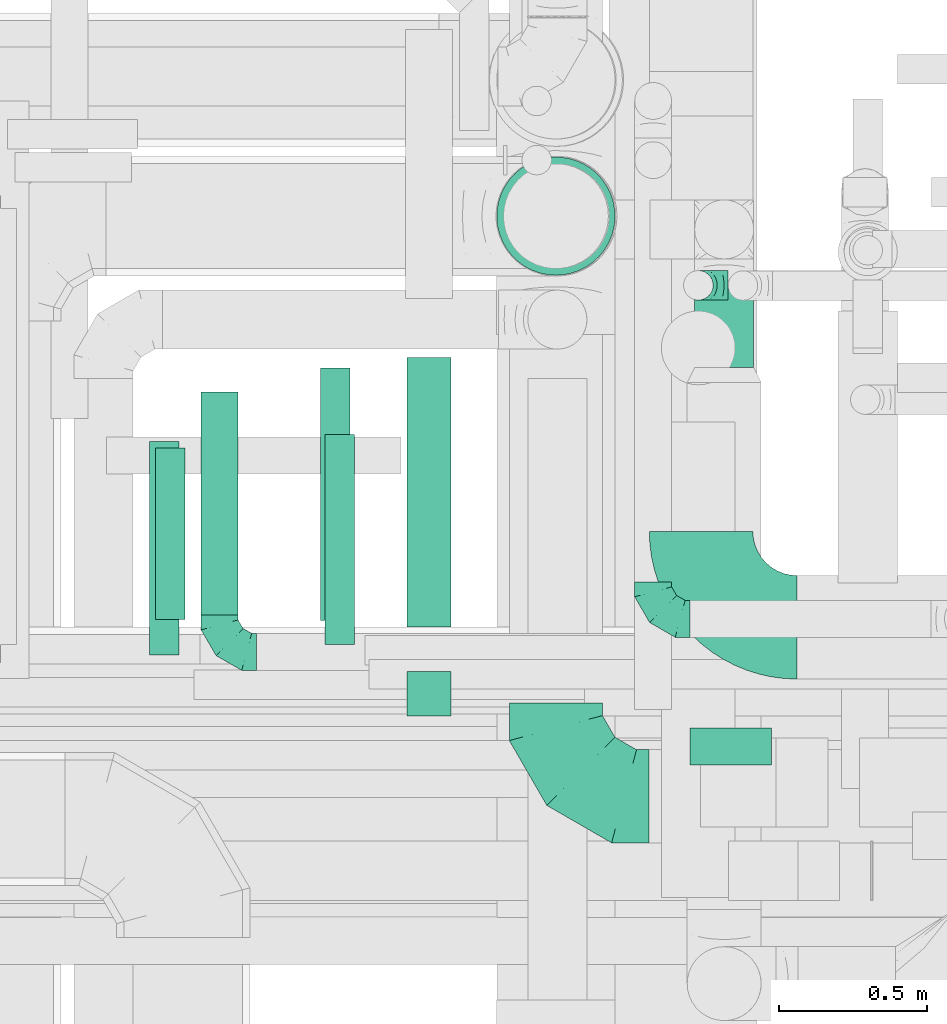
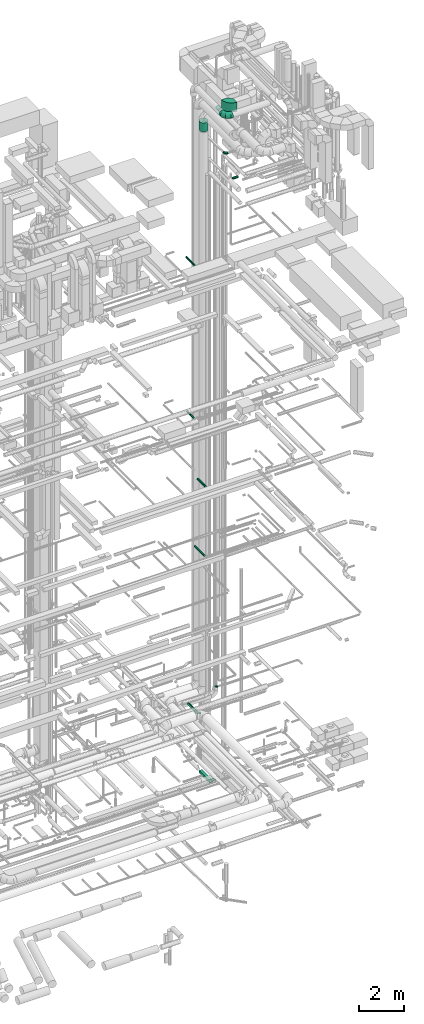
# One storey, part 260 of 337: 10 flow segments, 5 flow fittings.
"""IFC2X3 building model written with IfcOpenShell, lengths in millimetres."""

import ifcopenshell
import ifcopenshell.guid

model = None  # the IFC model being written
_history = None  # IfcOwnerHistory: only IFC2X3 demands one
_inside = {}  # id of a spatial element -> (the spatial element, [elements in it])
_under = {}  # id of a project, library or spatial element -> (it, [spatial elements below it])
_declared = {}  # id of a project -> (the project, [libraries it declares])
_typed = {}  # id of a type object -> (the type object, [elements of that type])
_made_of = {}  # id of a material, layer set ... -> (it, [elements and type objects made of it])


def new_model(schema):
    """Start an empty IFC model of exactly this schema.

    Asked for "IFC4X3", IfcOpenShell would pick the latest addendum, in which some entities
    have other attributes; the version numbers below select the first issue.
    IFC2X3 requires an IfcOwnerHistory on every rooted entity: one is made here for all.
    """
    global model, _history
    if schema == "IFC4X3":
        model = ifcopenshell.file(schema_version=(4, 3, 0, 0))
    else:
        model = ifcopenshell.file(schema=schema)
    _inside.clear()
    _under.clear()
    _declared.clear()
    _typed.clear()
    _made_of.clear()
    _history = None
    if model.schema == "IFC2X3":
        org = make("IfcOrganization", Name="unknown")
        user = make(
            "IfcPersonAndOrganization",
            ThePerson=make("IfcPerson", FamilyName="unknown"),
            TheOrganization=org,
        )
        app = make(
            "IfcApplication",
            ApplicationDeveloper=org,
            Version="unknown",
            ApplicationFullName="unknown",
            ApplicationIdentifier="unknown",
        )
        _history = make(
            "IfcOwnerHistory",
            OwningUser=user,
            OwningApplication=app,
            ChangeAction="ADDED",
            CreationDate=0,
        )
    return model


def make(cls, **values):
    """One entity of the class cls with the attributes given. An attribute that is None is left unset."""
    return model.create_entity(
        cls, **{name: value for name, value in values.items() if value is not None}
    )


def entity(cls, *values):
    """Any entity or typed value of the class cls, its attributes in the order of the schema. None: left unset."""
    e = model.create_entity(cls)
    for i, value in enumerate(values):
        if value is not None:
            e[i] = value
    return e


def rooted(cls, **values):
    """An entity with a GlobalId (a new one), such as an element, a storey or a relation."""
    return make(cls, GlobalId=ifcopenshell.guid.new(), OwnerHistory=_history, **values)


def si_unit(unit_type, name, prefix=None):
    """IfcSIUnit, for example si_unit("LENGTHUNIT", "METRE", prefix="MILLI")."""
    return make("IfcSIUnit", UnitType=unit_type, Prefix=prefix, Name=name)


def converted_unit(unit_type, name, factor, base, dimensions=None, offset=None):
    """IfcConversionBasedUnit, such as the inch: factor (a typed value) times the base unit."""
    return make(
        "IfcConversionBasedUnit"
        if offset is None
        else "IfcConversionBasedUnitWithOffset",
        ConversionOffset=offset,
        Dimensions=None
        if dimensions is None
        else entity("IfcDimensionalExponents", *dimensions),
        UnitType=unit_type,
        Name=name,
        ConversionFactor=make(
            "IfcMeasureWithUnit", ValueComponent=factor, UnitComponent=base
        ),
    )


def derived_unit(unit_type, elements):
    """IfcDerivedUnit: a product of units, each with its exponent."""
    return make(
        "IfcDerivedUnit",
        Elements=[
            make("IfcDerivedUnitElement", Unit=unit, Exponent=power)
            for unit, power in elements
        ],
        UnitType=unit_type,
    )


def assignment(units):
    """IfcUnitAssignment: the units of a project."""
    return None if units is None else make("IfcUnitAssignment", Units=units)


def point(xyz):
    """IfcCartesianPoint."""
    return None if xyz is None else make("IfcCartesianPoint", Coordinates=xyz)


def direction(xyz):
    """IfcDirection."""
    return None if xyz is None else make("IfcDirection", DirectionRatios=xyz)


def frame(location, z_axis=None, x_axis=None):
    """IfcAxis2Placement3D, a coordinate frame: its origin and axes. An axis left out is left unset."""
    return make(
        "IfcAxis2Placement3D",
        Location=point(location),
        Axis=direction(z_axis),
        RefDirection=direction(x_axis),
    )


def frame_2d(location, x_axis=None):
    """IfcAxis2Placement2D, a coordinate frame in the plane: its origin and x axis."""
    return make(
        "IfcAxis2Placement2D", Location=point(location), RefDirection=direction(x_axis)
    )


def origin():
    """The frame at (0, 0, 0) with its axes left unset."""
    return frame((0.0, 0.0, 0.0))


def origin_2d_with_axis():
    """The frame at (0, 0) in the plane with the x axis (1, 0) written out."""
    return frame_2d((0.0, 0.0), x_axis=(1.0, 0.0))


def place(relative_to, where):
    """IfcLocalPlacement: puts the frame where relative to a parent placement (None: the world)."""
    return make(
        "IfcLocalPlacement", PlacementRelTo=relative_to, RelativePlacement=where
    )


def context(
    kind, dimensions, precision=None, world=None, true_north=None, identifier=None
):
    """IfcGeometricRepresentationContext, for example the 3D "Model" context."""
    return make(
        "IfcGeometricRepresentationContext",
        ContextIdentifier=identifier,
        ContextType=kind,
        CoordinateSpaceDimension=dimensions,
        Precision=precision,
        WorldCoordinateSystem=world,
        TrueNorth=true_north,
    )


def subcontext(parent, identifier, kind, view, scale=None):
    """IfcGeometricRepresentationSubContext, for example "Body" below "Model"."""
    return make(
        "IfcGeometricRepresentationSubContext",
        ContextIdentifier=identifier,
        ContextType=kind,
        ParentContext=parent,
        TargetScale=scale,
        TargetView=view,
    )


def project(units=None, contexts=None):
    """IfcProject with its units and contexts."""
    return rooted(
        "IfcProject",
        Name="project",
        RepresentationContexts=contexts,
        UnitsInContext=assignment(units),
    )


def spatial(cls, under=None, at=None, **own):
    """A site, building, storey or space (cls), placed at a placement, below another one or the project."""
    s = rooted(cls, ObjectPlacement=at, **own)
    if under is not None:
        _under.setdefault(under.id(), (under, []))[1].append(s)
    return s


def polyline(points):
    """IfcPolyline through the points."""
    return make("IfcPolyline", Points=[point(p) for p in points])


def circle_curve(where, radius):
    """IfcCircle in the frame where."""
    return make("IfcCircle", Position=where, Radius=radius)


def parameter(value):
    """IfcParameterValue: where a trimmed curve begins or ends, as a parameter of its basis curve."""
    return model.create_entity("IfcParameterValue", value)


def trimmed(basis, trim1, trim2, sense, master):
    """IfcTrimmedCurve: the piece of a basis curve between two trims."""
    return make(
        "IfcTrimmedCurve",
        BasisCurve=basis,
        Trim1=trim1,
        Trim2=trim2,
        SenseAgreement=sense,
        MasterRepresentation=master,
    )


def segment(curve, same_sense, transition):
    """IfcCompositeCurveSegment."""
    return make(
        "IfcCompositeCurveSegment",
        Transition=transition,
        SameSense=same_sense,
        ParentCurve=curve,
    )


def composite_curve(segments, self_intersect=None):
    """IfcCompositeCurve: segments joined end to end."""
    return make("IfcCompositeCurve", Segments=segments, SelfIntersect=self_intersect)


def profile(cls, at=None, kind="AREA", **sizes):
    """A parametric profile (cls). Its sizes go by their IFC names, for example OverallWidth=200.0."""
    return make(cls, ProfileType=kind, Position=at, **sizes)


def rectangle(**sizes):
    """IfcRectangleProfileDef."""
    return profile("IfcRectangleProfileDef", **sizes)


def circle(**sizes):
    """IfcCircleProfileDef."""
    return profile("IfcCircleProfileDef", **sizes)


def outline(outer, holes=None, kind="AREA"):
    """IfcArbitraryClosedProfileDef: a profile drawn as a closed curve; with holes, ...WithVoids."""
    if holes is None:
        return make("IfcArbitraryClosedProfileDef", ProfileType=kind, OuterCurve=outer)
    return make(
        "IfcArbitraryProfileDefWithVoids",
        ProfileType=kind,
        OuterCurve=outer,
        InnerCurves=holes,
    )


def extrude(swept, where, along, depth):
    """IfcExtrudedAreaSolid: the profile swept, set in the frame where, extruded along a direction by depth."""
    return make(
        "IfcExtrudedAreaSolid",
        SweptArea=swept,
        Position=where,
        ExtrudedDirection=direction(along),
        Depth=depth,
    )


def faces_of(points, faces, orient=None, outer=None):
    """IfcFace entities. A face is a list of loops; a loop is a list of indices into points, from 0.

    orient and outer hold one flag for each loop. By default every Orientation is true, the
    first loop of a face is its IfcFaceOuterBound and the others are IfcFaceBound.
    """
    made = []
    for i, loops in enumerate(faces):
        bounds = []
        for j, loop in enumerate(loops):
            is_outer = j == 0 if outer is None else outer[i][j]
            bounds.append(
                make(
                    "IfcFaceOuterBound" if is_outer else "IfcFaceBound",
                    Bound=make("IfcPolyLoop", Polygon=[points[k] for k in loop]),
                    Orientation=True if orient is None else orient[i][j],
                )
            )
        made.append(make("IfcFace", Bounds=bounds))
    return made


def faceted_brep(points, faces, orient=None, outer=None, voids=None):
    """IfcFacetedBrep: a solid bounded by flat faces; with voids (closed shells), ...WithVoids."""
    shared = [point(p) for p in points]
    hull = make("IfcClosedShell", CfsFaces=faces_of(shared, faces, orient, outer))
    if voids is None:
        return make("IfcFacetedBrep", Outer=hull)
    return make(
        "IfcFacetedBrepWithVoids",
        Outer=hull,
        Voids=[
            make(cls, CfsFaces=faces_of(shared, fs, o, b)) for cls, fs, o, b in voids
        ],
    )


def shape(context_of_items, identifier, shape_type, items):
    """IfcShapeRepresentation: the items that make up one representation, for example the "Body"."""
    return make(
        "IfcShapeRepresentation",
        ContextOfItems=context_of_items,
        RepresentationIdentifier=identifier,
        RepresentationType=shape_type,
        Items=items,
    )


def source(mapping_origin, context_of_items, identifier, shape_type, items):
    """IfcRepresentationMap: a shape defined once, which mapped items show again and again."""
    return make(
        "IfcRepresentationMap",
        MappingOrigin=mapping_origin,
        MappedRepresentation=shape(context_of_items, identifier, shape_type, items),
    )


def transform(
    local_origin,
    x_axis=None,
    y_axis=None,
    z_axis=None,
    scale=None,
    scale2=None,
    scale3=None,
    uniform=True,
):
    """IfcCartesianTransformationOperator3D, or its non-uniform kind. x_axis, y_axis, z_axis: its Axis1, 2, 3."""
    if uniform:
        return make(
            "IfcCartesianTransformationOperator3D",
            Axis1=direction(x_axis),
            Axis2=direction(y_axis),
            LocalOrigin=point(local_origin),
            Scale=scale,
            Axis3=direction(z_axis),
        )
    return make(
        "IfcCartesianTransformationOperator3DnonUniform",
        Axis1=direction(x_axis),
        Axis2=direction(y_axis),
        LocalOrigin=point(local_origin),
        Scale=scale,
        Axis3=direction(z_axis),
        Scale2=scale2,
        Scale3=scale3,
    )


def mapped(mapping_source, mapping_target):
    """IfcMappedItem: shows the shape of a source again, moved by a transform."""
    return make(
        "IfcMappedItem", MappingSource=mapping_source, MappingTarget=mapping_target
    )


def material(Name=None, Category=None):
    """IfcMaterial."""
    return make("IfcMaterial", Name=Name, Category=Category)


def made_of(thing, what):
    """Note that an element or type object is made of a material, layer set ...; save() writes the relation."""
    if what is not None:
        _made_of.setdefault(what.id(), (what, []))[1].append(thing)
    return thing


def type_object(cls, material=None, **own):
    """A type object (cls), such as IfcWallType, which elements share."""
    return made_of(rooted(cls, **own), material)


def type_shapes(of_type, sources):
    """Give a type object the sources (RepresentationMaps) that its elements show as mapped items."""
    of_type.RepresentationMaps = sources


def element(
    cls,
    number,
    at=None,
    inside=None,
    cuts=None,
    type_object=None,
    material=None,
    context=None,
    identifier="Body",
    shape_type=None,
    held_by="IfcProductDefinitionShape",
    body=None,
    shapes=None,
    **own,
):
    """One element of the class cls, such as IfcWall. Its Tag is "e" and its number.

    at: its placement. inside: the storey or other place that contains it. cuts: it is an
    opening in that element (IfcRelVoidsElement). A single representation is given by context,
    identifier, shape_type and body (its items); several are given by shapes. held_by: the class
    of the entity that holds the representations. save() writes the other relations.
    """
    e = rooted(cls, Tag="e%d" % number, ObjectPlacement=at, **own)
    if body is not None:
        shapes = [shape(context, identifier, shape_type, body)]
    if shapes is not None:
        e.Representation = make(held_by, Representations=shapes)
    if inside is not None:
        _inside.setdefault(inside.id(), (inside, []))[1].append(e)
    if cuts is not None:
        rooted(
            "IfcRelVoidsElement", RelatingBuildingElement=cuts, RelatedOpeningElement=e
        )
    if type_object is not None:
        _typed.setdefault(type_object.id(), (type_object, []))[1].append(e)
    return made_of(e, material)


def aggregate(whole, parts):
    """IfcRelAggregates: a whole, such as a stair, and the parts it consists of."""
    return rooted("IfcRelAggregates", RelatingObject=whole, RelatedObjects=parts)


def save(model, path):
    """Write the relations noted so far, then the file.

    IfcRelAggregates (storeys below a building ...), IfcRelContainedInSpatialStructure (elements
    in a storey), IfcRelDefinesByType, IfcRelAssociatesMaterial and IfcRelDeclares: one each for
    every whole, place, type object, material and project.
    """
    for whole, parts in _under.values():
        aggregate(whole, parts)
    for where, things in _inside.values():
        rooted(
            "IfcRelContainedInSpatialStructure",
            RelatedElements=things,
            RelatingStructure=where,
        )
    for kind, things in _typed.values():
        rooted("IfcRelDefinesByType", RelatedObjects=things, RelatingType=kind)
    for what, things in _made_of.values():
        rooted("IfcRelAssociatesMaterial", RelatedObjects=things, RelatingMaterial=what)
    for by, libraries in _declared.values():
        rooted("IfcRelDeclares", RelatingContext=by, RelatedDefinitions=libraries)
    model.write(path)


model = new_model("IFC2X3")

# Units and contexts
model_context = context("Model", 3, precision=0.01, world=origin(), true_north=direction((6.12303176911189e-17, 1.0)))
body_context = subcontext(model_context, "Body", "Model", "MODEL_VIEW")
ifc_project = project(units=[si_unit("LENGTHUNIT", "METRE", prefix="MILLI"), si_unit("AREAUNIT", "SQUARE_METRE"), si_unit("VOLUMEUNIT", "CUBIC_METRE"), converted_unit("PLANEANGLEUNIT", "DEGREE", entity("IfcRatioMeasure", 0.0174532925199433), si_unit("PLANEANGLEUNIT", "RADIAN"), dimensions=[0, 0, 0, 0, 0, 0, 0]), si_unit("MASSUNIT", "GRAM", prefix="KILO"), derived_unit("MASSDENSITYUNIT", [(si_unit("MASSUNIT", "GRAM", prefix="KILO"), 1), (si_unit("LENGTHUNIT", "METRE"), -3)]), derived_unit("MOMENTOFINERTIAUNIT", [(si_unit("LENGTHUNIT", "METRE"), 4)]), si_unit("TIMEUNIT", "SECOND"), si_unit("FREQUENCYUNIT", "HERTZ"), si_unit("THERMODYNAMICTEMPERATUREUNIT", "DEGREE_CELSIUS"), derived_unit("THERMALTRANSMITTANCEUNIT", [(si_unit("MASSUNIT", "GRAM", prefix="KILO"), 1), (si_unit("THERMODYNAMICTEMPERATUREUNIT", "KELVIN"), -1), (si_unit("TIMEUNIT", "SECOND"), -3)]), derived_unit("VOLUMETRICFLOWRATEUNIT", [(si_unit("LENGTHUNIT", "METRE"), 3), (si_unit("TIMEUNIT", "SECOND"), -1)]), derived_unit("MASSFLOWRATEUNIT", [(si_unit("MASSUNIT", "GRAM", prefix="KILO"), 1), (si_unit("TIMEUNIT", "SECOND"), -1)]), derived_unit("ROTATIONALFREQUENCYUNIT", [(si_unit("TIMEUNIT", "SECOND"), -1)]), si_unit("ELECTRICCURRENTUNIT", "AMPERE"), si_unit("ELECTRICVOLTAGEUNIT", "VOLT"), si_unit("POWERUNIT", "WATT"), si_unit("FORCEUNIT", "NEWTON", prefix="KILO"), si_unit("ILLUMINANCEUNIT", "LUX"), si_unit("LUMINOUSFLUXUNIT", "LUMEN"), si_unit("LUMINOUSINTENSITYUNIT", "CANDELA"), derived_unit("USERDEFINED", [(si_unit("MASSUNIT", "GRAM", prefix="KILO"), -1), (si_unit("LENGTHUNIT", "METRE"), -2), (si_unit("TIMEUNIT", "SECOND"), 3), (si_unit("LUMINOUSFLUXUNIT", "LUMEN"), 1)]), derived_unit("LINEARVELOCITYUNIT", [(si_unit("LENGTHUNIT", "METRE"), 1), (si_unit("TIMEUNIT", "SECOND"), -1)]), si_unit("PRESSUREUNIT", "PASCAL"), derived_unit("USERDEFINED", [(si_unit("LENGTHUNIT", "METRE"), -2), (si_unit("MASSUNIT", "GRAM", prefix="KILO"), 1), (si_unit("TIMEUNIT", "SECOND"), -2)]), derived_unit("LINEARFORCEUNIT", [(si_unit("MASSUNIT", "GRAM", prefix="KILO"), 1), (si_unit("LENGTHUNIT", "METRE"), 1), (si_unit("TIMEUNIT", "SECOND"), -2), (si_unit("LENGTHUNIT", "METRE"), -1)]), derived_unit("PLANARFORCEUNIT", [(si_unit("MASSUNIT", "GRAM", prefix="KILO"), 1), (si_unit("LENGTHUNIT", "METRE"), 1), (si_unit("TIMEUNIT", "SECOND"), -2), (si_unit("LENGTHUNIT", "METRE"), -2)])], contexts=[model_context])

# Site, building, storey
site_placement = place(None, origin())
site = spatial("IfcSite", under=ifc_project, at=site_placement, CompositionType="ELEMENT")
building_placement = place(site_placement, origin())
building = spatial("IfcBuilding", under=site, at=building_placement, CompositionType="ELEMENT")
storey_placement = place(building_placement, origin())
storey = spatial("IfcBuildingStorey", under=building, at=storey_placement, CompositionType="ELEMENT", Elevation=0.0)

# Flow segments
duct_segment_type_1 = type_object("IfcDuctSegmentType", PredefinedType="NOTDEFINED")
flow_segment_1_placement = place(storey_placement, frame((67054.73, 10099.06, -675.0)))
element("IfcFlowSegment", 1, at=flow_segment_1_placement, inside=storey, type_object=duct_segment_type_1, context=body_context, shape_type="SweptSolid", body=[
    extrude(rectangle(XDim=150.000000000001, YDim=150.000000000001, at=origin_2d_with_axis()), frame((75.0, 75.0, 0.0), z_axis=(0.0, 0.0, 1.0), x_axis=(0.0, 1.0, 0.0)), (0.0, 0.0, 1.0), 30.0000000000121),
])
flow_segment_2_placement = place(storey_placement, frame((67054.73, 10399.06, -975.0)))
element("IfcFlowSegment", 2, at=flow_segment_2_placement, inside=storey, type_object=duct_segment_type_1, context=body_context, shape_type="SweptSolid", body=[
    extrude(rectangle(XDim=912.000000000007, YDim=150.000000000001, at=origin_2d_with_axis()), frame((75.0, 456.0, 0.0), z_axis=(0.0, 0.0, 1.0), x_axis=(0.0, 1.0, 0.0)), (0.0, 0.0, 1.0), 150.0),
])
duct_segment_type_2 = type_object("IfcDuctSegmentType", PredefinedType="NOTDEFINED")
flow_segment_3_placement = place(storey_placement, frame((66776.28, 10340.36, 15248.4)))
element("IfcFlowSegment", 3, at=flow_segment_3_placement, inside=storey, type_object=duct_segment_type_2, context=body_context, shape_type="SweptSolid", body=[
    extrude(circle(Radius=50.0, at=origin_2d_with_axis()), frame((51.6, 0.0, 51.6), z_axis=(0.0, 1.0, 0.0), x_axis=(1.0, 0.0, 0.0)), (0.0, 0.0, 1.0), 710.000000000005),
])
flow_segment_4_placement = place(storey_placement, frame((66761.5, 10421.33, 11448.4)))
element("IfcFlowSegment", 4, at=flow_segment_4_placement, inside=storey, type_object=duct_segment_type_2, context=body_context, shape_type="SweptSolid", body=[
    extrude(circle(Radius=50.0, at=origin_2d_with_axis()), frame((51.6, 0.0, 51.6), z_axis=(0.0, 1.0, 0.0), x_axis=(1.0, 0.0, 0.0)), (0.0, 0.0, 1.0), 855.000000000018),
])
flow_segment_5_placement = place(storey_placement, frame((66357.85, 10440.5, 3035.9)))
element("IfcFlowSegment", 5, at=flow_segment_5_placement, inside=storey, type_object=duct_segment_type_2, context=body_context, shape_type="SweptSolid", body=[
    extrude(circle(Radius=62.5, at=origin_2d_with_axis()), frame((64.1, 0.0, 64.1), z_axis=(0.0, 1.0, 0.0), x_axis=(1.0, 0.0, 0.0)), (0.0, 0.0, 1.0), 754.74944733785),
])
flow_segment_6_placement = place(storey_placement, frame((66203.23, 10425.19, 19148.4)))
element("IfcFlowSegment", 6, at=flow_segment_6_placement, inside=storey, type_object=duct_segment_type_2, context=body_context, shape_type="SweptSolid", body=[
    extrude(circle(Radius=50.0, at=origin_2d_with_axis()), frame((51.6, 0.0, 51.6), z_axis=(0.0, 1.0, 0.0), x_axis=(1.0, 0.0, 0.0)), (0.0, 0.0, 1.0), 580.000000000011),
])
flow_segment_7_placement = place(storey_placement, frame((67357.45, 11587.56, 33630.0)))
element("IfcFlowSegment", 7, at=flow_segment_7_placement, inside=storey, type_object=duct_segment_type_2, context=body_context, shape_type="SweptSolid", body=[
    extrude(circle(Radius=200.0, at=origin_2d_with_axis()), frame((201.6, 201.6, 0.0), z_axis=(0.0, 0.0, 1.0), x_axis=(0.0, -1.0, 0.0)), (0.0, 0.0, 1.0), 490.000000420803),
])
flow_segment_8_placement = place(storey_placement, frame((68026.5, 11277.11, 34698.4)))
element("IfcFlowSegment", 8, at=flow_segment_8_placement, inside=storey, type_object=duct_segment_type_2, context=body_context, shape_type="SweptSolid", body=[
    extrude(circle(Radius=100.0, at=origin_2d_with_axis()), frame((101.6, 0.0, 101.6), z_axis=(0.0, 1.0, 0.0), x_axis=(1.0, 0.0, 0.0)), (0.0, 0.0, 1.0), 267.178690553049),
])
flow_segment_9_placement = place(storey_placement, frame((66183.28, 10305.08, 27548.4)))
element("IfcFlowSegment", 9, at=flow_segment_9_placement, inside=storey, type_object=duct_segment_type_2, context=body_context, shape_type="SweptSolid", body=[
    extrude(circle(Radius=50.0, at=origin_2d_with_axis()), frame((51.6, 0.0, 51.6), z_axis=(0.0, 1.0, 0.0), x_axis=(1.0, 0.0, 0.0)), (0.0, 0.0, 1.0), 722.500000000022),
])
flow_segment_10_placement = place(storey_placement, frame((68013.0, 9931.15, 31825.9)))
element("IfcFlowSegment", 10, at=flow_segment_10_placement, inside=storey, type_object=duct_segment_type_2, context=body_context, shape_type="SweptSolid", body=[
    extrude(circle(Radius=62.5, at=origin_2d_with_axis()), frame((0.0, 64.1, 64.1), z_axis=(1.0, 0.0, 0.0), x_axis=(0.0, 1.0, 0.0)), (0.0, 0.0, 1.0), 275.797196645982),
])

# Flow fittings
ifc_material = material()
duct_fitting_type_1 = type_object("IfcDuctFittingType", PredefinedType="NOTDEFINED", material=ifc_material)
shared_shape_1 = source(origin(), body_context, "Body", "Brep", [
    faceted_brep([(-100.0, 0.0, -50.0), (-100.0, -12.94, -48.3), (-100.0, -25.0, -43.3), (-100.0, -35.36, -35.36), (-100.0, -43.3, -25.0), (-100.0, -48.3, -12.94), (-100.0, -50.0, 0.0), (-100.0, -48.3, 12.94), (-100.0, -43.3, 25.0), (-100.0, -35.36, 35.36), (-100.0, -25.0, 43.3), (-100.0, -12.94, 48.3), (-100.0, 0.0, 50.0), (-100.0, 12.94, 48.3), (-100.0, 25.0, 43.3), (-100.0, 35.36, 35.36), (-100.0, 43.3, 25.0), (-100.0, 48.3, 12.94), (-100.0, 50.0, 0.0), (-100.0, 48.3, -12.94), (-100.0, 43.3, -25.0), (-100.0, 35.36, -35.36), (-100.0, 25.0, -43.3), (-100.0, 12.94, -48.3), (-76.67, 12.94, 48.3), (-79.9, 25.0, 43.3), (-73.21, 0.0, 50.0), (-82.68, 35.36, 35.36), (-86.15, 48.3, 12.94), (-86.6, 50.0, 0.0), (-84.81, 43.3, 25.0), (-84.81, 43.3, -25.0), (-82.68, 35.36, -35.36), (-86.15, 48.3, -12.94), (-76.67, 12.94, -48.3), (-73.21, 0.0, -50.0), (-79.9, 25.0, -43.3), (-69.74, -12.94, -48.3), (-66.51, -25.0, -43.3), (-63.73, -35.36, -35.36), (-61.6, -43.3, -25.0), (-60.26, -48.3, -12.94), (-59.81, -50.0, 0.0), (-60.26, -48.3, 12.94), (-61.6, -43.3, 25.0), (-63.73, -35.36, 35.36), (-66.51, -25.0, 43.3), (-69.74, -12.94, 48.3), (-36.27, 36.27, 48.3), (-45.1, 45.1, 43.3), (-26.79, 26.79, 50.0), (-52.68, 52.68, 35.36), (-58.49, 58.49, 25.0), (-62.15, 62.15, 12.94), (-63.4, 63.4, 0.0), (-62.15, 62.15, -12.94), (-58.49, 58.49, -25.0), (-52.68, 52.68, -35.36), (-36.27, 36.27, -48.3), (-26.79, 26.79, -50.0), (-45.1, 45.1, -43.3), (-17.32, 17.32, -48.3), (-8.49, 8.49, -43.3), (-0.91, 0.91, -35.36), (4.9, -4.9, -25.0), (8.56, -8.56, -12.94), (9.81, -9.81, 0.0), (8.56, -8.56, 12.94), (4.9, -4.9, 25.0), (-0.91, 0.91, 35.36), (-8.49, 8.49, 43.3), (-17.32, 17.32, 48.3), (-12.94, 76.67, 48.3), (-25.0, 79.9, 43.3), (0.0, 73.21, 50.0), (-35.36, 82.68, 35.36), (-43.3, 84.81, 25.0), (-48.3, 86.15, 12.94), (-50.0, 86.6, 0.0), (-48.3, 86.15, -12.94), (-43.3, 84.81, -25.0), (-35.36, 82.68, -35.36), (-12.94, 76.67, -48.3), (0.0, 73.21, -50.0), (-25.0, 79.9, -43.3), (12.94, 69.74, -48.3), (25.0, 66.51, -43.3), (35.36, 63.73, -35.36), (43.3, 61.6, -25.0), (48.3, 60.26, -12.94), (50.0, 59.81, 0.0), (48.3, 60.26, 12.94), (43.3, 61.6, 25.0), (35.36, 63.73, 35.36), (25.0, 66.51, 43.3), (12.94, 69.74, 48.3), (-12.94, 100.0, -48.3), (-25.0, 100.0, -43.3), (-35.36, 100.0, -35.36), (-43.3, 100.0, -25.0), (-48.3, 100.0, -12.94), (-50.0, 100.0, 0.0), (-48.3, 100.0, 12.94), (-43.3, 100.0, 25.0), (-35.36, 100.0, 35.36), (-25.0, 100.0, 43.3), (-12.94, 100.0, 48.3), (0.0, 100.0, 50.0), (12.94, 100.0, 48.3), (25.0, 100.0, 43.3), (35.36, 100.0, 35.36), (43.3, 100.0, 25.0), (48.3, 100.0, 12.94), (50.0, 100.0, 0.0), (48.3, 100.0, -12.94), (43.3, 100.0, -25.0), (35.36, 100.0, -35.36), (25.0, 100.0, -43.3), (12.94, 100.0, -48.3), (0.0, 100.0, -50.0)], [[[0, 1, 2, 3, 4, 5, 6, 7, 8, 9, 10, 11, 12, 13, 14, 15, 16, 17, 18, 19, 20, 21, 22, 23]], [[24, 25, 14, 13]], [[26, 24, 13, 12]], [[14, 25, 27, 15]], [[28, 29, 18, 17]], [[30, 28, 17, 16]], [[15, 27, 30, 16]], [[20, 31, 32, 21]], [[33, 31, 20, 19]], [[18, 29, 33, 19]], [[34, 35, 0, 23]], [[36, 34, 23, 22]], [[32, 36, 22, 21]], [[2, 1, 37, 38]], [[3, 2, 38, 39]], [[0, 35, 37, 1]], [[5, 4, 40, 41]], [[6, 5, 41, 42]], [[3, 39, 40, 4]], [[6, 42, 43, 7]], [[7, 43, 44, 8]], [[8, 44, 45, 9]], [[10, 46, 47, 11]], [[11, 47, 26, 12]], [[10, 9, 45, 46]], [[48, 49, 25, 24]], [[50, 48, 24, 26]], [[27, 25, 49, 51]], [[52, 53, 28, 30]], [[51, 52, 30, 27]], [[29, 28, 53, 54]], [[55, 56, 31, 33]], [[54, 55, 33, 29]], [[57, 32, 31, 56]], [[58, 59, 35, 34]], [[60, 58, 34, 36]], [[57, 60, 36, 32]], [[37, 35, 59, 61]], [[38, 37, 61, 62]], [[39, 38, 62, 63]], [[41, 40, 64, 65]], [[42, 41, 65, 66]], [[63, 64, 40, 39]], [[43, 42, 66, 67]], [[44, 43, 67, 68]], [[68, 69, 45, 44]], [[46, 45, 69, 70]], [[47, 46, 70, 71]], [[26, 47, 71, 50]], [[72, 73, 49, 48]], [[74, 72, 48, 50]], [[51, 49, 73, 75]], [[76, 77, 53, 52]], [[75, 76, 52, 51]], [[54, 53, 77, 78]], [[79, 80, 56, 55]], [[78, 79, 55, 54]], [[81, 57, 56, 80]], [[82, 83, 59, 58]], [[84, 82, 58, 60]], [[81, 84, 60, 57]], [[61, 59, 83, 85]], [[62, 61, 85, 86]], [[63, 62, 86, 87]], [[65, 64, 88, 89]], [[66, 65, 89, 90]], [[87, 88, 64, 63]], [[67, 66, 90, 91]], [[68, 67, 91, 92]], [[92, 93, 69, 68]], [[70, 69, 93, 94]], [[71, 70, 94, 95]], [[50, 71, 95, 74]], [[96, 97, 98, 99, 100, 101, 102, 103, 104, 105, 106, 107, 108, 109, 110, 111, 112, 113, 114, 115, 116, 117, 118, 119]], [[72, 74, 107, 106]], [[73, 72, 106, 105]], [[75, 73, 105, 104]], [[77, 76, 103, 102]], [[78, 77, 102, 101]], [[75, 104, 103, 76]], [[78, 101, 100, 79]], [[79, 100, 99, 80]], [[80, 99, 98, 81]], [[96, 119, 83, 82]], [[97, 96, 82, 84]], [[84, 81, 98, 97]], [[83, 119, 118, 85]], [[85, 118, 117, 86]], [[86, 117, 116, 87]], [[88, 115, 114, 89]], [[89, 114, 113, 90]], [[87, 116, 115, 88]], [[91, 90, 113, 112]], [[92, 91, 112, 111]], [[93, 92, 111, 110]], [[95, 94, 109, 108]], [[74, 95, 108, 107]], [[110, 109, 94, 93]]]),
])
type_shapes(duct_fitting_type_1, [shared_shape_1])
flow_fitting_1_placement = place(storey_placement, frame((68040.83, 11555.25, 3220.0), z_axis=(0.0, 1.0, 0.0), x_axis=(-1.0, 0.0, 0.0)))
element("IfcFlowFitting", 11, at=flow_fitting_1_placement, inside=storey, type_object=duct_fitting_type_1, material=ifc_material, context=body_context, shape_type="MappedRepresentation", body=[
    mapped(shared_shape_1, transform((0.0, 0.0, 0.0), scale=1.0)),
])
duct_fitting_type_2 = type_object("IfcDuctFittingType", PredefinedType="NOTDEFINED", material=ifc_material)
shared_shape_2 = source(origin(), body_context, "Body", "Brep", [
    faceted_brep([(-125.0, 0.0, -62.5), (-125.0, -16.18, -60.37), (-125.0, -31.25, -54.13), (-125.0, -44.19, -44.19), (-125.0, -54.13, -31.25), (-125.0, -60.37, -16.18), (-125.0, -62.5, 0.0), (-125.0, -60.37, 16.18), (-125.0, -54.13, 31.25), (-125.0, -44.19, 44.19), (-125.0, -31.25, 54.13), (-125.0, -16.18, 60.37), (-125.0, 0.0, 62.5), (-125.0, 16.18, 60.37), (-125.0, 31.25, 54.13), (-125.0, 44.19, 44.19), (-125.0, 54.13, 31.25), (-125.0, 60.37, 16.18), (-125.0, 62.5, 0.0), (-125.0, 60.37, -16.18), (-125.0, 54.13, -31.25), (-125.0, 44.19, -44.19), (-125.0, 31.25, -54.13), (-125.0, 16.18, -60.37), (-95.84, 16.18, 60.37), (-99.88, 31.25, 54.13), (-91.51, 0.0, 62.5), (-103.35, 44.19, 44.19), (-107.68, 60.37, 16.18), (-108.25, 62.5, 0.0), (-106.01, 54.13, 31.25), (-106.01, 54.13, -31.25), (-103.35, 44.19, -44.19), (-107.68, 60.37, -16.18), (-95.84, 16.18, -60.37), (-91.51, 0.0, -62.5), (-99.88, 31.25, -54.13), (-87.17, -16.18, -60.37), (-83.13, -31.25, -54.13), (-79.66, -44.19, -44.19), (-77.0, -54.13, -31.25), (-75.33, -60.37, -16.18), (-74.76, -62.5, 0.0), (-75.33, -60.37, 16.18), (-77.0, -54.13, 31.25), (-79.66, -44.19, 44.19), (-83.13, -31.25, 54.13), (-87.17, -16.18, 60.37), (-45.34, 45.34, 60.37), (-56.37, 56.37, 54.13), (-33.49, 33.49, 62.5), (-65.85, 65.85, 44.19), (-73.12, 73.12, 31.25), (-77.69, 77.69, 16.18), (-79.25, 79.25, 0.0), (-77.69, 77.69, -16.18), (-73.12, 73.12, -31.25), (-65.85, 65.85, -44.19), (-45.34, 45.34, -60.37), (-33.49, 33.49, -62.5), (-56.37, 56.37, -54.13), (-21.65, 21.65, -60.37), (-10.62, 10.62, -54.13), (-1.14, 1.14, -44.19), (6.13, -6.13, -31.25), (10.7, -10.7, -16.18), (12.26, -12.26, 0.0), (10.7, -10.7, 16.18), (6.13, -6.13, 31.25), (-1.14, 1.14, 44.19), (-10.62, 10.62, 54.13), (-21.65, 21.65, 60.37), (-16.18, 95.84, 60.37), (-31.25, 99.88, 54.13), (0.0, 91.51, 62.5), (-44.19, 103.35, 44.19), (-54.13, 106.01, 31.25), (-60.37, 107.68, 16.18), (-62.5, 108.25, 0.0), (-60.37, 107.68, -16.18), (-54.13, 106.01, -31.25), (-44.19, 103.35, -44.19), (-16.18, 95.84, -60.37), (0.0, 91.51, -62.5), (-31.25, 99.88, -54.13), (16.18, 87.17, -60.37), (31.25, 83.13, -54.13), (44.19, 79.66, -44.19), (54.13, 77.0, -31.25), (60.37, 75.33, -16.18), (62.5, 74.76, 0.0), (60.37, 75.33, 16.18), (54.13, 77.0, 31.25), (44.19, 79.66, 44.19), (31.25, 83.13, 54.13), (16.18, 87.17, 60.37), (-16.18, 125.0, -60.37), (-31.25, 125.0, -54.13), (-44.19, 125.0, -44.19), (-54.13, 125.0, -31.25), (-60.37, 125.0, -16.18), (-62.5, 125.0, 0.0), (-60.37, 125.0, 16.18), (-54.13, 125.0, 31.25), (-44.19, 125.0, 44.19), (-31.25, 125.0, 54.13), (-16.18, 125.0, 60.37), (0.0, 125.0, 62.5), (16.18, 125.0, 60.37), (31.25, 125.0, 54.13), (44.19, 125.0, 44.19), (54.13, 125.0, 31.25), (60.37, 125.0, 16.18), (62.5, 125.0, 0.0), (60.37, 125.0, -16.18), (54.13, 125.0, -31.25), (44.19, 125.0, -44.19), (31.25, 125.0, -54.13), (16.18, 125.0, -60.37), (0.0, 125.0, -62.5)], [[[0, 1, 2, 3, 4, 5, 6, 7, 8, 9, 10, 11, 12, 13, 14, 15, 16, 17, 18, 19, 20, 21, 22, 23]], [[24, 25, 14, 13]], [[26, 24, 13, 12]], [[14, 25, 27, 15]], [[28, 29, 18, 17]], [[30, 28, 17, 16]], [[15, 27, 30, 16]], [[20, 31, 32, 21]], [[33, 31, 20, 19]], [[18, 29, 33, 19]], [[34, 35, 0, 23]], [[36, 34, 23, 22]], [[21, 32, 36, 22]], [[1, 0, 35, 37]], [[2, 1, 37, 38]], [[38, 39, 3, 2]], [[5, 4, 40, 41]], [[6, 5, 41, 42]], [[39, 40, 4, 3]], [[6, 42, 43, 7]], [[7, 43, 44, 8]], [[45, 9, 8, 44]], [[9, 45, 46, 10]], [[10, 46, 47, 11]], [[26, 12, 11, 47]], [[48, 49, 25, 24]], [[50, 48, 24, 26]], [[27, 25, 49, 51]], [[52, 53, 28, 30]], [[51, 52, 30, 27]], [[29, 28, 53, 54]], [[55, 56, 31, 33]], [[54, 55, 33, 29]], [[57, 32, 31, 56]], [[58, 59, 35, 34]], [[60, 58, 34, 36]], [[57, 60, 36, 32]], [[37, 35, 59, 61]], [[38, 37, 61, 62]], [[39, 38, 62, 63]], [[41, 40, 64, 65]], [[42, 41, 65, 66]], [[63, 64, 40, 39]], [[43, 42, 66, 67]], [[44, 43, 67, 68]], [[68, 69, 45, 44]], [[46, 45, 69, 70]], [[47, 46, 70, 71]], [[26, 47, 71, 50]], [[72, 73, 49, 48]], [[74, 72, 48, 50]], [[51, 49, 73, 75]], [[76, 77, 53, 52]], [[75, 76, 52, 51]], [[54, 53, 77, 78]], [[79, 80, 56, 55]], [[78, 79, 55, 54]], [[81, 57, 56, 80]], [[82, 83, 59, 58]], [[84, 82, 58, 60]], [[81, 84, 60, 57]], [[61, 59, 83, 85]], [[62, 61, 85, 86]], [[63, 62, 86, 87]], [[65, 64, 88, 89]], [[66, 65, 89, 90]], [[87, 88, 64, 63]], [[67, 66, 90, 91]], [[68, 67, 91, 92]], [[92, 93, 69, 68]], [[70, 69, 93, 94]], [[71, 70, 94, 95]], [[50, 71, 95, 74]], [[96, 97, 98, 99, 100, 101, 102, 103, 104, 105, 106, 107, 108, 109, 110, 111, 112, 113, 114, 115, 116, 117, 118, 119]], [[72, 74, 107, 106]], [[73, 72, 106, 105]], [[75, 73, 105, 104]], [[77, 76, 103, 102]], [[78, 77, 102, 101]], [[75, 104, 103, 76]], [[78, 101, 100, 79]], [[79, 100, 99, 80]], [[80, 99, 98, 81]], [[96, 119, 83, 82]], [[97, 96, 82, 84]], [[84, 81, 98, 97]], [[83, 119, 118, 85]], [[85, 118, 117, 86]], [[116, 87, 86, 117]], [[88, 115, 114, 89]], [[89, 114, 113, 90]], [[115, 88, 87, 116]], [[91, 90, 113, 112]], [[92, 91, 112, 111]], [[111, 110, 93, 92]], [[95, 94, 109, 108]], [[74, 95, 108, 107]], [[110, 109, 94, 93]]]),
])
type_shapes(duct_fitting_type_2, [shared_shape_2])
for number, where, z_axis, x_axis in (
    (12, (67888.0, 10427.27, 33015.0), (0.0, 0.0, 1.0), (0.0, -1.0, 0.0)),
    (13, (66421.95, 10315.5, 3100.0), (0.0, 0.0, 1.0), (0.0, -1.0, 0.0)),
):
    element("IfcFlowFitting", number, at=place(storey_placement, frame(where, z_axis=z_axis, x_axis=x_axis)), inside=storey, type_object=duct_fitting_type_2, material=ifc_material, context=body_context, shape_type="MappedRepresentation", body=[
        mapped(shared_shape_2, transform((0.0, 0.0, 0.0), scale=1.0)),
    ])
duct_fitting_type_3 = type_object("IfcDuctFittingType", PredefinedType="NOTDEFINED", material=ifc_material)
shared_shape_3 = source(origin(), body_context, "Body", "Brep", [
    faceted_brep([(-315.0, 0.0, -157.5), (-315.0, -40.76, -152.13), (-315.0, -78.75, -136.4), (-315.0, -111.37, -111.37), (-315.0, -136.4, -78.75), (-315.0, -152.13, -40.76), (-315.0, -157.5, 0.0), (-315.0, -152.13, 40.76), (-315.0, -136.4, 78.75), (-315.0, -111.37, 111.37), (-315.0, -78.75, 136.4), (-315.0, -40.76, 152.13), (-315.0, 0.0, 157.5), (-315.0, 40.76, 152.13), (-315.0, 78.75, 136.4), (-315.0, 111.37, 111.37), (-315.0, 136.4, 78.75), (-315.0, 152.13, 40.76), (-315.0, 157.5, 0.0), (-315.0, 152.13, -40.76), (-315.0, 136.4, -78.75), (-315.0, 111.37, -111.37), (-315.0, 78.75, -136.4), (-315.0, 40.76, -152.13), (-241.52, 40.76, 152.13), (-251.7, 78.75, 136.4), (-230.6, 0.0, 157.5), (-260.44, 111.37, 111.37), (-271.36, 152.13, 40.76), (-272.8, 157.5, 0.0), (-267.14, 136.4, 78.75), (-267.14, 136.4, -78.75), (-260.44, 111.37, -111.37), (-271.36, 152.13, -40.76), (-241.52, 40.76, -152.13), (-230.6, 0.0, -157.5), (-251.7, 78.75, -136.4), (-219.67, -40.76, -152.13), (-209.5, -78.75, -136.4), (-200.75, -111.37, -111.37), (-194.05, -136.4, -78.75), (-189.83, -152.13, -40.76), (-188.39, -157.5, 0.0), (-189.83, -152.13, 40.76), (-194.05, -136.4, 78.75), (-200.75, -111.37, 111.37), (-209.5, -78.75, 136.4), (-219.67, -40.76, 152.13), (-114.25, 114.25, 152.13), (-142.05, 142.05, 136.4), (-84.4, 84.4, 157.5), (-165.93, 165.93, 111.37), (-184.25, 184.25, 78.75), (-195.77, 195.77, 40.76), (-199.7, 199.7, 0.0), (-195.77, 195.77, -40.76), (-184.25, 184.25, -78.75), (-165.93, 165.93, -111.37), (-114.25, 114.25, -152.13), (-84.4, 84.4, -157.5), (-142.05, 142.05, -136.4), (-54.56, 54.56, -152.13), (-26.75, 26.75, -136.4), (-2.88, 2.88, -111.37), (15.45, -15.45, -78.75), (26.97, -26.97, -40.76), (30.89, -30.89, 0.0), (26.97, -26.97, 40.76), (15.45, -15.45, 78.75), (-2.88, 2.88, 111.37), (-26.75, 26.75, 136.4), (-54.56, 54.56, 152.13), (-40.76, 241.52, 152.13), (-78.75, 251.7, 136.4), (0.0, 230.6, 157.5), (-111.37, 260.44, 111.37), (-136.4, 267.14, 78.75), (-152.13, 271.36, 40.76), (-157.5, 272.8, 0.0), (-152.13, 271.36, -40.76), (-136.4, 267.14, -78.75), (-111.37, 260.44, -111.37), (-40.76, 241.52, -152.13), (0.0, 230.6, -157.5), (-78.75, 251.7, -136.4), (40.76, 219.67, -152.13), (78.75, 209.5, -136.4), (111.37, 200.75, -111.37), (136.4, 194.05, -78.75), (152.13, 189.83, -40.76), (157.5, 188.39, 0.0), (152.13, 189.83, 40.76), (136.4, 194.05, 78.75), (111.37, 200.75, 111.37), (78.75, 209.5, 136.4), (40.76, 219.67, 152.13), (-40.76, 315.0, -152.13), (-78.75, 315.0, -136.4), (-111.37, 315.0, -111.37), (-136.4, 315.0, -78.75), (-152.13, 315.0, -40.76), (-157.5, 315.0, 0.0), (-152.13, 315.0, 40.76), (-136.4, 315.0, 78.75), (-111.37, 315.0, 111.37), (-78.75, 315.0, 136.4), (-40.76, 315.0, 152.13), (0.0, 315.0, 157.5), (40.76, 315.0, 152.13), (78.75, 315.0, 136.4), (111.37, 315.0, 111.37), (136.4, 315.0, 78.75), (152.13, 315.0, 40.76), (157.5, 315.0, 0.0), (152.13, 315.0, -40.76), (136.4, 315.0, -78.75), (111.37, 315.0, -111.37), (78.75, 315.0, -136.4), (40.76, 315.0, -152.13), (0.0, 315.0, -157.5)], [[[0, 1, 2, 3, 4, 5, 6, 7, 8, 9, 10, 11, 12, 13, 14, 15, 16, 17, 18, 19, 20, 21, 22, 23]], [[24, 25, 14, 13]], [[26, 24, 13, 12]], [[14, 25, 27, 15]], [[28, 29, 18, 17]], [[30, 28, 17, 16]], [[15, 27, 30, 16]], [[20, 31, 32, 21]], [[33, 31, 20, 19]], [[18, 29, 33, 19]], [[34, 35, 0, 23]], [[36, 34, 23, 22]], [[32, 36, 22, 21]], [[1, 0, 35, 37]], [[2, 1, 37, 38]], [[38, 39, 3, 2]], [[5, 4, 40, 41]], [[6, 5, 41, 42]], [[39, 40, 4, 3]], [[6, 42, 43, 7]], [[7, 43, 44, 8]], [[8, 44, 45, 9]], [[9, 45, 46, 10]], [[10, 46, 47, 11]], [[26, 12, 11, 47]], [[48, 49, 25, 24]], [[50, 48, 24, 26]], [[27, 25, 49, 51]], [[52, 53, 28, 30]], [[51, 52, 30, 27]], [[29, 28, 53, 54]], [[55, 56, 31, 33]], [[54, 55, 33, 29]], [[32, 31, 56, 57]], [[58, 59, 35, 34]], [[60, 58, 34, 36]], [[57, 60, 36, 32]], [[37, 35, 59, 61]], [[38, 37, 61, 62]], [[39, 38, 62, 63]], [[41, 40, 64, 65]], [[42, 41, 65, 66]], [[63, 64, 40, 39]], [[43, 42, 66, 67]], [[44, 43, 67, 68]], [[68, 69, 45, 44]], [[46, 45, 69, 70]], [[47, 46, 70, 71]], [[26, 47, 71, 50]], [[72, 73, 49, 48]], [[74, 72, 48, 50]], [[51, 49, 73, 75]], [[76, 77, 53, 52]], [[75, 76, 52, 51]], [[54, 53, 77, 78]], [[79, 80, 56, 55]], [[78, 79, 55, 54]], [[57, 56, 80, 81]], [[82, 83, 59, 58]], [[84, 82, 58, 60]], [[81, 84, 60, 57]], [[61, 59, 83, 85]], [[62, 61, 85, 86]], [[63, 62, 86, 87]], [[65, 64, 88, 89]], [[66, 65, 89, 90]], [[87, 88, 64, 63]], [[67, 66, 90, 91]], [[68, 67, 91, 92]], [[92, 93, 69, 68]], [[70, 69, 93, 94]], [[71, 70, 94, 95]], [[50, 71, 95, 74]], [[96, 97, 98, 99, 100, 101, 102, 103, 104, 105, 106, 107, 108, 109, 110, 111, 112, 113, 114, 115, 116, 117, 118, 119]], [[106, 105, 73, 72]], [[107, 106, 72, 74]], [[75, 73, 105, 104]], [[77, 76, 103, 102]], [[78, 77, 102, 101]], [[104, 103, 76, 75]], [[78, 101, 100, 79]], [[79, 100, 99, 80]], [[98, 81, 80, 99]], [[84, 97, 96, 82]], [[82, 96, 119, 83]], [[97, 84, 81, 98]], [[83, 119, 118, 85]], [[85, 118, 117, 86]], [[116, 87, 86, 117]], [[88, 115, 114, 89]], [[89, 114, 113, 90]], [[115, 88, 87, 116]], [[91, 90, 113, 112]], [[92, 91, 112, 111]], [[111, 110, 93, 92]], [[95, 94, 109, 108]], [[74, 95, 108, 107]], [[110, 109, 94, 93]]]),
])
type_shapes(duct_fitting_type_3, [shared_shape_3])
flow_fitting_2_placement = place(storey_placement, frame((67559.05, 9827.35, 35520.0), z_axis=(0.0, 0.0, 1.0), x_axis=(0.0, -1.0, 0.0)))
element("IfcFlowFitting", 14, at=flow_fitting_2_placement, inside=storey, type_object=duct_fitting_type_3, material=ifc_material, context=body_context, shape_type="MappedRepresentation", body=[
    mapped(shared_shape_3, transform((0.0, 0.0, 0.0), scale=1.0)),
])
duct_fitting_type_4 = type_object("IfcDuctFittingType", PredefinedType="NOTDEFINED", material=ifc_material)
shared_shape_4 = source(origin(), body_context, "Body", "SweptSolid", [
    extrude(outline(composite_curve([segment(polyline([(-337.5, -162.5), (12.5, -162.5)]), True, "CONTINUOUS"), segment(trimmed(circle_curve(frame_2d((162.5, -162.5), x_axis=(0.0, 1.0)), 150.0), [parameter(0.0)], [parameter(90.0000000000001)], True, "PARAMETER"), False, "CONTINUOUS"), segment(polyline([(162.5, -12.5), (162.5, 337.5)]), True, "CONTINUOUS"), segment(trimmed(circle_curve(frame_2d((162.5, -162.5), x_axis=(0.0, 1.0)), 500.0), [parameter(0.0)], [parameter(90.0000000000001)], True, "PARAMETER"), True, "CONTINUOUS")], self_intersect=False)), frame((-162.5, 162.5, -250.0), z_axis=(0.0, 0.0, 1.0), x_axis=(-1.0, 0.0, 0.0)), (0.0, 0.0, 1.0), 500.0),
])
type_shapes(duct_fitting_type_4, [shared_shape_4])
flow_fitting_3_placement = place(storey_placement, frame((68049.87, 10398.58, 35530.0), z_axis=(0.0, 0.0, 1.0), x_axis=(0.0, -1.0, 0.0)))
element("IfcFlowFitting", 15, at=flow_fitting_3_placement, inside=storey, type_object=duct_fitting_type_4, material=ifc_material, context=body_context, shape_type="MappedRepresentation", body=[
    mapped(shared_shape_4, transform((0.0, 0.0, 0.0), scale=1.0)),
])

save(model, "model.ifc")
